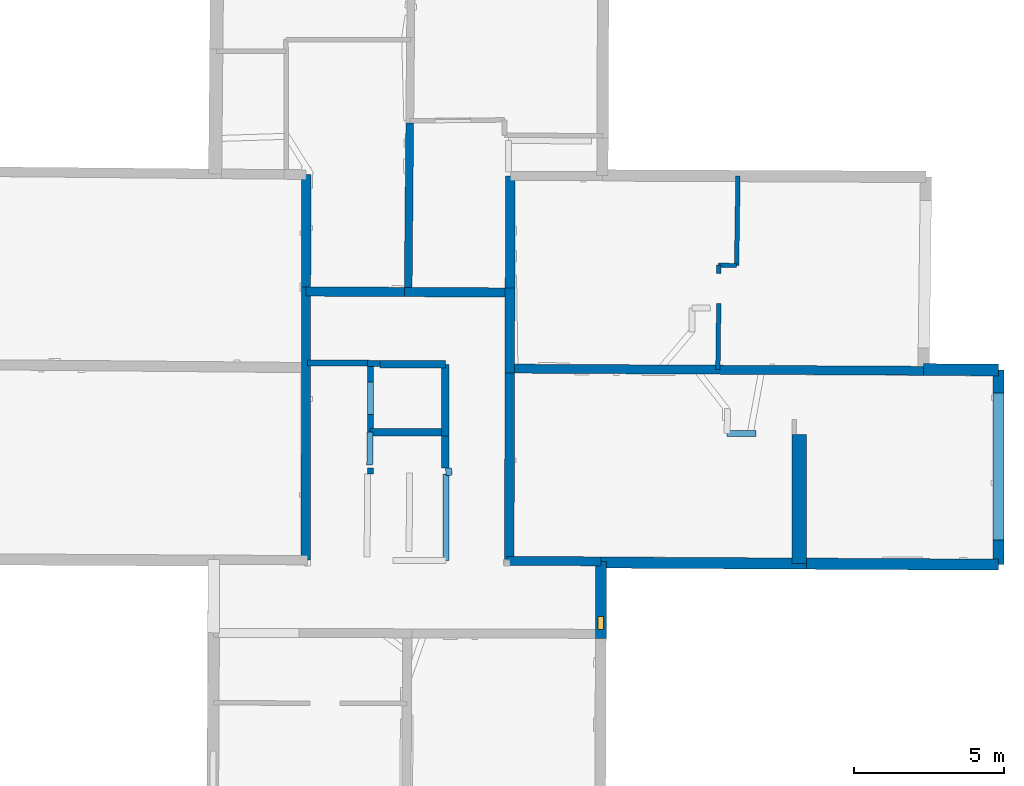
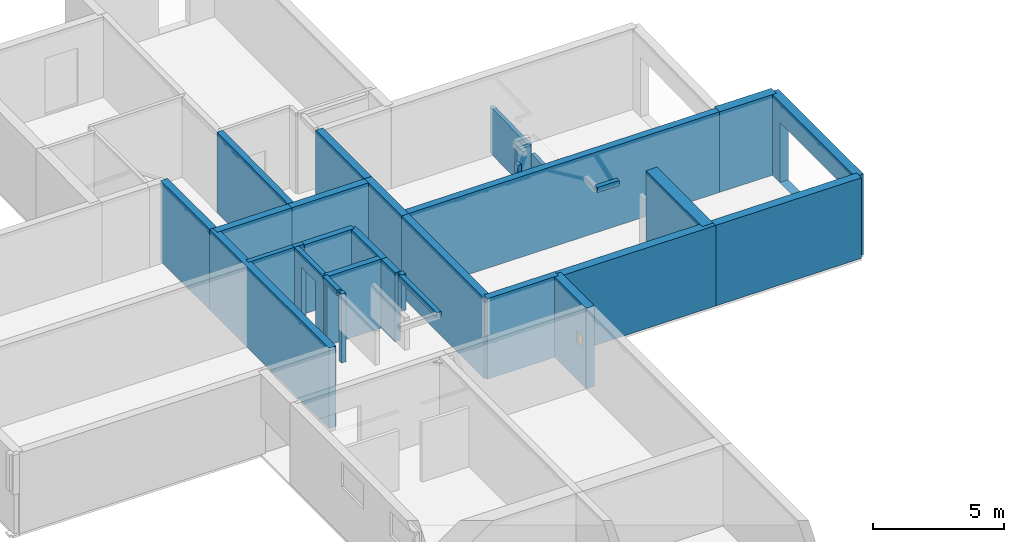
# One storey, part 6 of 12: 32 walls, 1 window, 3 openings.
"""IFC2X3 building model written with IfcOpenShell, lengths in metres."""

from ifc_helpers import new_model, entity, si_unit, converted_unit, derived_unit, direction, frame, frame_2d, origin, origin_2d_with_axis, place, context, subcontext, project, spatial, polyline, rectangle, outline, extrude, source, transform, mapped, material, layer, layer_set, layer_usage, type_object, type_shapes, element, fill, save


model = new_model("IFC2X3")

# Units and contexts
model_context = context("Model", 3, precision=1e-05, world=origin(), true_north=direction((0.0, 1.0)))
body_context = subcontext(model_context, "Body", "Model", "MODEL_VIEW")
ifc_project = project(units=[si_unit("LENGTHUNIT", "METRE"), si_unit("AREAUNIT", "SQUARE_METRE"), si_unit("VOLUMEUNIT", "CUBIC_METRE"), converted_unit("PLANEANGLEUNIT", "DEGREE", entity("IfcRatioMeasure", 0.0174532925199433), si_unit("PLANEANGLEUNIT", "RADIAN"), dimensions=[0, 0, 0, 0, 0, 0, 0]), si_unit("MASSUNIT", "GRAM", prefix="KILO"), derived_unit("MASSDENSITYUNIT", [(si_unit("MASSUNIT", "GRAM", prefix="KILO"), 1), (si_unit("LENGTHUNIT", "METRE"), -3)]), derived_unit("MOMENTOFINERTIAUNIT", [(si_unit("LENGTHUNIT", "METRE"), 4)]), si_unit("TIMEUNIT", "SECOND"), si_unit("FREQUENCYUNIT", "HERTZ"), si_unit("THERMODYNAMICTEMPERATUREUNIT", "DEGREE_CELSIUS"), derived_unit("THERMALTRANSMITTANCEUNIT", [(si_unit("MASSUNIT", "GRAM", prefix="KILO"), 1), (si_unit("THERMODYNAMICTEMPERATUREUNIT", "KELVIN"), -1), (si_unit("TIMEUNIT", "SECOND"), -3)]), derived_unit("VOLUMETRICFLOWRATEUNIT", [(si_unit("LENGTHUNIT", "METRE"), 3), (si_unit("TIMEUNIT", "SECOND"), -1)]), si_unit("ELECTRICCURRENTUNIT", "AMPERE"), si_unit("ELECTRICVOLTAGEUNIT", "VOLT"), si_unit("POWERUNIT", "WATT"), si_unit("FORCEUNIT", "NEWTON", prefix="KILO"), si_unit("ILLUMINANCEUNIT", "LUX"), si_unit("LUMINOUSFLUXUNIT", "LUMEN"), si_unit("LUMINOUSINTENSITYUNIT", "CANDELA"), derived_unit("USERDEFINED", [(si_unit("MASSUNIT", "GRAM", prefix="KILO"), -1), (si_unit("LENGTHUNIT", "METRE"), -2), (si_unit("TIMEUNIT", "SECOND"), 3), (si_unit("LUMINOUSFLUXUNIT", "LUMEN"), 1)]), derived_unit("LINEARVELOCITYUNIT", [(si_unit("LENGTHUNIT", "METRE"), 1), (si_unit("TIMEUNIT", "SECOND"), -1)]), si_unit("PRESSUREUNIT", "PASCAL"), derived_unit("USERDEFINED", [(si_unit("LENGTHUNIT", "METRE"), -2), (si_unit("MASSUNIT", "GRAM", prefix="KILO"), 1), (si_unit("TIMEUNIT", "SECOND"), -2)]), derived_unit("LINEARFORCEUNIT", [(si_unit("MASSUNIT", "GRAM", prefix="KILO"), 1), (si_unit("LENGTHUNIT", "METRE"), 1), (si_unit("TIMEUNIT", "SECOND"), -2), (si_unit("LENGTHUNIT", "METRE"), -1)]), derived_unit("PLANARFORCEUNIT", [(si_unit("MASSUNIT", "GRAM", prefix="KILO"), 1), (si_unit("LENGTHUNIT", "METRE"), 1), (si_unit("TIMEUNIT", "SECOND"), -2), (si_unit("LENGTHUNIT", "METRE"), -2)])], contexts=[model_context])

# Site, building, storey
placement_1 = place(None, origin())
site = spatial("IfcSite", under=ifc_project, at=placement_1, CompositionType="ELEMENT")
building = spatial("IfcBuilding", under=site, at=placement_1, CompositionType="ELEMENT")
storey_placement = place(placement_1, frame((0.0, 0.0, -1.46125340461731)))
storey = spatial("IfcBuildingStorey", under=building, at=storey_placement, Name="Level 1", CompositionType="ELEMENT", Elevation=-1.46125340461731)

# Walls
ifc_material_1 = material(Name="Default wall")
ifc_layer_1 = layer(ifc_material_1, 0.25)
ifc_layer_set_1 = layer_set([ifc_layer_1], Name="wall_thickness_0.2500")
ifc_layer_usage_1 = layer_usage(ifc_layer_set_1, "AXIS2", "POSITIVE", -0.125)
wall_type_1 = type_object("IfcWallType", Name="wall_thickness_0.2500", PredefinedType="STANDARD", material=ifc_layer_set_1)
placement_2 = place(placement_1, frame((0.0, 0.0, -0.920999705791473)))
wall_1_placement = place(placement_2, frame((5.0991297330923, 55.5079187408588, 0.0), z_axis=(0.0, 0.0, 1.0), x_axis=(0.999995431107156, -0.0030228736017967, 0.0)))
element("IfcWallStandardCase", 1, at=wall_1_placement, inside=storey, type_object=wall_type_1, material=ifc_layer_usage_1, Name="Wall:584", ObjectType="Wall", context=body_context, shape_type="SweptSolid", body=[
    extrude(outline(polyline([(2.50622082412851, -0.125), (2.50622082412851, 0.125), (0.0, 0.125), (0.0, -0.125), (2.50622082412851, -0.125)])), origin(), (0.0, 0.0, 1.0), 3.20173248052597),
])
placement_3 = place(placement_1, frame((0.0, 0.0, -0.920999705791473)))
wall_2_placement = place(placement_3, frame((5.42314035019711, 57.770520756905, 0.0), z_axis=(0.0, 0.0, 1.0), x_axis=(0.999988008085666, -0.00489731404561275, 0.0)))
element("IfcWallStandardCase", 2, at=wall_2_placement, inside=storey, type_object=wall_type_1, material=ifc_layer_usage_1, Name="Wall:603", ObjectType="Wall", context=body_context, shape_type="SweptSolid", body=[
    extrude(outline(polyline([(2.18258041831252, -0.125), (2.18258041831252, 0.125), (0.0, 0.125), (0.0, -0.125), (2.18258041831252, -0.125)])), origin(), (0.0, 0.0, 1.0), 3.20173248052597),
])
placement_4 = place(placement_1, frame((0.0, 0.0, -0.920999705791473)))
wall_3_placement = place(placement_4, frame((7.60569477235314, 57.7598348384197, 0.0), z_axis=(0.0, 0.0, 1.0), x_axis=(-0.00015717987903363, -0.999999987647243, 0.0)))
element("IfcWallStandardCase", 3, at=wall_3_placement, inside=storey, type_object=wall_type_1, material=ifc_layer_usage_1, Name="Wall:614", ObjectType="Wall", context=body_context, shape_type="SweptSolid", body=[
    extrude(outline(polyline([(2.38449099625191, -0.125), (2.38449099625191, 0.125), (0.0, 0.125), (0.0, -0.125), (2.38449099625191, -0.125)])), origin(), (0.0, 0.0, 1.0), 3.20173248052597),
])
placement_5 = place(placement_1, frame((0.0, 0.0, -0.920999705791473)))
wall_4_placement = place(placement_5, frame((7.60531997834679, 55.3753438716228, 0.0), z_axis=(0.0, 0.0, 1.0), x_axis=(-0.000157016468550762, -0.999999987672914, 0.0)))
element("IfcWallStandardCase", 4, at=wall_4_placement, inside=storey, type_object=wall_type_1, material=ifc_layer_usage_1, Name="Wall:615", ObjectType="Wall", context=body_context, shape_type="SweptSolid", body=[
    extrude(outline(polyline([(1.05682755819362, -0.125), (1.05682755819362, 0.125), (0.0, 0.125), (0.0, -0.125), (1.05682755819362, -0.125)])), origin(), (0.0, 0.0, 1.0), 3.20173248052597),
])
ifc_layer_2 = layer(ifc_material_1, 0.2)
ifc_layer_set_2 = layer_set([ifc_layer_2], Name="wall_thickness_0.2000")
ifc_layer_usage_2 = layer_usage(ifc_layer_set_2, "AXIS2", "POSITIVE", -0.1)
wall_type_2 = type_object("IfcWallType", Name="wall_thickness_0.2000", PredefinedType="STANDARD", material=ifc_layer_set_2)
placement_6 = place(placement_1, frame((0.0, 0.0, 2.04199981689453)))
wall_5_placement = place(placement_6, frame((16.9757748002958, 55.4680153708994, 0.0), z_axis=(0.0, 0.0, 1.0), x_axis=(0.99996270094869, -0.00863693877487449, 0.0)))
element("IfcWallStandardCase", 5, at=wall_5_placement, inside=storey, type_object=wall_type_2, material=ifc_layer_usage_2, Name="Wall:542", ObjectType="Wall", context=body_context, shape_type="SweptSolid", body=[
    extrude(outline(polyline([(0.957545710053407, -0.1), (0.957545710053407, 0.1), (0.0, 0.1), (0.0, -0.1), (0.957545710053407, -0.1)])), origin(), (0.0, 0.0, 1.0), 0.238732957839966),
])
placement_7 = place(placement_1, frame((0.0, 0.0, 0.585000038146973)))
wall_6_placement = place(placement_7, frame((7.71784101377591, 54.0699024277879, 0.0), z_axis=(0.0, 0.0, 1.0), x_axis=(-0.0227928941877033, 0.999740208241395, 0.0)))
element("IfcWallStandardCase", 6, at=wall_6_placement, inside=storey, type_object=wall_type_2, material=ifc_layer_usage_2, Name="Wall:550", ObjectType="Wall", context=body_context, shape_type="SweptSolid", body=[
    extrude(outline(polyline([(0.239999178421907, -0.1), (0.239999178421907, 0.1), (0.0, 0.1), (0.0, -0.1), (0.239999178421907, -0.1)])), origin(), (0.0, 0.0, 1.0), 1.69573273658752),
])
placement_8 = place(placement_1, frame((0.0, 0.0, 2.04199981689453)))
wall_7_placement = place(placement_8, frame((5.08565149901211, 54.4163982963928, 0.0), z_axis=(0.0, 0.0, 1.0), x_axis=(0.0123472078364718, 0.99992377032384, 0.0)))
element("IfcWallStandardCase", 7, at=wall_7_placement, inside=storey, type_object=wall_type_2, material=ifc_layer_usage_2, Name="Wall:597", ObjectType="Wall", context=body_context, shape_type="SweptSolid", body=[
    extrude(outline(polyline([(1.09160542952526, -0.1), (1.09160542952526, 0.1), (0.0, 0.1), (0.0, -0.1), (1.09160542952526, -0.1)])), origin(), (0.0, 0.0, 1.0), 0.238732957839966),
])
placement_9 = place(placement_1, frame((0.0, 0.0, -0.920999705791473)))
wall_8_placement = place(placement_9, frame((3.00986537965636, 57.807349833775, 0.0), z_axis=(0.0, 0.0, 1.0), x_axis=(0.999987997594505, -0.00489945577916829, 0.0)))
element("IfcWallStandardCase", 8, at=wall_8_placement, inside=storey, type_object=wall_type_2, material=ifc_layer_usage_2, Name="Wall:601", ObjectType="Wall", context=body_context, shape_type="SweptSolid", body=[
    extrude(outline(polyline([(1.9970990508642, -0.1), (1.9970990508642, 0.1), (0.0, 0.1), (0.0, -0.1), (1.9970990508642, -0.1)])), origin(), (0.0, 0.0, 1.0), 3.20173248052597),
])
placement_10 = place(placement_1, frame((0.0, 0.0, -0.920999705791473)))
wall_9_placement = place(placement_10, frame((5.00694046052794, 57.7975651352887, 0.0), z_axis=(0.0, 0.0, 1.0), x_axis=(0.999987984808634, -0.00490206470457369, 0.0)))
element("IfcWallStandardCase", 9, at=wall_9_placement, inside=storey, type_object=wall_type_2, material=ifc_layer_usage_2, Name="Wall:602", ObjectType="Wall", context=body_context, shape_type="SweptSolid", body=[
    extrude(outline(polyline([(0.416327233544107, -0.1), (0.416327233544107, 0.1), (0.0, 0.1), (0.0, -0.1), (0.416327233544107, -0.1)])), origin(), (0.0, 0.0, 1.0), 3.20173248052597),
])
placement_11 = place(placement_1, frame((0.0, 0.0, -0.920999705791473)))
wall_10_placement = place(placement_11, frame((5.11326645856321, 54.3175500420287, 0.0), z_axis=(0.0, 0.0, 1.0), x_axis=(-0.0103440014207659, -0.999946499386146, 0.0)))
element("IfcWallStandardCase", 10, at=wall_10_placement, inside=storey, type_object=wall_type_2, material=ifc_layer_usage_2, Name="Wall:642", ObjectType="Wall", context=body_context, shape_type="SweptSolid", body=[
    extrude(outline(polyline([(0.204997539759841, -0.1), (0.204997539759841, 0.1), (0.0, 0.1), (0.0, -0.1), (0.204997539759841, -0.1)])), origin(), (0.0, 0.0, 1.0), 3.20173248052597),
])

# Wall, opening
placement_12 = place(placement_1, frame((0.0, 0.0, -0.920999705791473)))
wall_11_placement = place(placement_12, frame((5.1182845221847, 55.507865807687, 0.0), z_axis=(0.0, 0.0, 1.0), x_axis=(-0.00495805451237965, 0.999987708772189, 0.0)))
wall_11 = element("IfcWallStandardCase", 11, at=wall_11_placement, inside=storey, type_object=wall_type_2, material=ifc_layer_usage_2, Name="Wall:677", ObjectType="Wall", context=body_context, shape_type="SweptSolid", body=[
    extrude(outline(polyline([(2.28923559601232, -0.1), (2.28923559601232, 0.1), (0.0, 0.1), (0.0, -0.1), (2.28923559601232, -0.1)])), origin(), (0.0, 0.0, 1.0), 3.20173248052597),
])
opening_1_placement = place(wall_11_placement, frame((0.577159338640721, -0.1, 0.0170002579689026)))
element("IfcOpeningElement", 12, at=opening_1_placement, cuts=wall_11, Name="Opening : 1085 x 2585 : 430", ObjectType="Opening", context=body_context, shape_type="SweptSolid", body=[
    extrude(rectangle(XDim=1.085, YDim=2.585, at=frame_2d((1.2925, 0.5425), x_axis=(0.0, 1.0))), frame((0.0, 0.0, 0.0), z_axis=(0.0, 1.0, 0.0), x_axis=(0.0, 0.0, 1.0)), (0.0, 0.0, 1.0), 0.2),
])

# Wall
ifc_layer_3 = layer(ifc_material_1, 0.259999990463257)
ifc_layer_set_3 = layer_set([ifc_layer_3], Name="wall_thickness_0.2600")
ifc_layer_usage_3 = layer_usage(ifc_layer_set_3, "AXIS2", "POSITIVE", -0.129999995231628)
wall_type_3 = type_object("IfcWallType", Name="wall_thickness_0.2600", PredefinedType="STANDARD", material=ifc_layer_set_3)
wall_12_placement = place(storey_placement, frame((6.41707185678893, 65.78650920034, 0.0), z_axis=(0.0, 0.0, 1.0), x_axis=(-0.00925303609033537, -0.999957189745197, 0.0)))
element("IfcWallStandardCase", 13, at=wall_12_placement, inside=storey, type_object=wall_type_3, material=ifc_layer_usage_3, Name="Wall:624", ObjectType="Wall", context=body_context, shape_type="SweptSolid", body=[
    extrude(outline(polyline([(5.61936974755893, -0.129999995231628), (5.61936974755893, 0.129999995231628), (0.0, 0.129999995231628), (0.0, -0.129999995231628), (5.61936974755893, -0.129999995231628)])), origin(), (0.0, 0.0, 1.0), 3.74198617935181),
])

# Wall, opening
ifc_layer_4 = layer(ifc_material_1, 0.370000004768372)
ifc_layer_set_4 = layer_set([ifc_layer_4], Name="wall_thickness_0.3700")
ifc_layer_usage_4 = layer_usage(ifc_layer_set_4, "AXIS2", "POSITIVE", -0.185000002384186)
wall_type_4 = type_object("IfcWallType", Name="wall_thickness_0.3700", PredefinedType="STANDARD", material=ifc_layer_set_4)
wall_13_placement = place(storey_placement, frame((26.0007051826948, 57.5693012363224, 0.0), z_axis=(0.0, 0.0, 1.0), x_axis=(-3.9191118849826e-05, -0.999999999232028, 0.0)))
wall_13 = element("IfcWallStandardCase", 14, at=wall_13_placement, inside=storey, type_object=wall_type_4, material=ifc_layer_usage_4, Name="Wall:523", ObjectType="Wall", context=body_context, shape_type="SweptSolid", body=[
    extrude(outline(polyline([(6.4728279163479, -0.185000002384186), (6.4728279163479, 0.185000002384186), (0.0, 0.185000002384186), (0.0, -0.185000002384186), (6.4728279163479, -0.185000002384186)])), origin(), (0.0, 0.0, 1.0), 3.74198617935181),
])
opening_2_placement = place(wall_13_placement, frame((0.755805979989141, -0.185000002384186, 0.00725388526916504)))
element("IfcOpeningElement", 15, at=opening_2_placement, cuts=wall_13, Name="Opening : 4900 x 2770 : 407", ObjectType="Opening", context=body_context, shape_type="SweptSolid", body=[
    extrude(rectangle(XDim=4.9, YDim=2.77, at=frame_2d((1.385, 2.45), x_axis=(0.0, 1.0))), frame((0.0, 0.0, 0.0), z_axis=(0.0, 1.0, 0.0), x_axis=(0.0, 0.0, 1.0)), (0.0, 0.0, 1.0), 0.370000004768372),
])

# Walls
wall_14_placement = place(storey_placement, frame((12.7834272632515, 51.1682316821907, 0.0), z_axis=(0.0, 0.0, 1.0), x_axis=(0.99998526317627, -0.00542894375427323, 0.0)))
element("IfcWallStandardCase", 16, at=wall_14_placement, inside=storey, type_object=wall_type_4, material=ifc_layer_usage_4, Name="Wall:563", ObjectType="Wall", context=body_context, shape_type="SweptSolid", body=[
    extrude(outline(polyline([(6.83476602120401, -0.185000002384186), (6.83476602120401, 0.185000002384186), (0.0, 0.185000002384186), (0.0, -0.185000002384186), (6.83476602120401, -0.185000002384186)])), origin(), (0.0, 0.0, 1.0), 3.74198617935181),
])
wall_15_placement = place(storey_placement, frame((19.6180925617134, 51.1311261218879, 0.0), z_axis=(0.0, 0.0, 1.0), x_axis=(0.999985264095711, -0.00542877439489841, 0.0)))
element("IfcWallStandardCase", 17, at=wall_15_placement, inside=storey, type_object=wall_type_4, material=ifc_layer_usage_4, Name="Wall:564", ObjectType="Wall", context=body_context, shape_type="SweptSolid", body=[
    extrude(outline(polyline([(6.38245260223607, -0.185000002384186), (6.38245260223607, 0.185000002384186), (0.0, 0.185000002384186), (0.0, -0.185000002384186), (6.38245260223607, -0.185000002384186)])), origin(), (0.0, 0.0, 1.0), 3.74198617935181),
])
ifc_layer_5 = layer(ifc_material_1, 0.200000002980232)
ifc_layer_set_5 = layer_set([ifc_layer_5], Name="wall_thickness_0.2000")
ifc_layer_usage_5 = layer_usage(ifc_layer_set_5, "AXIS2", "POSITIVE", -0.100000001490116)
wall_type_5 = type_object("IfcWallType", Name="wall_thickness_0.2000", PredefinedType="STANDARD", material=ifc_layer_set_5)
placement_13 = place(placement_1, frame((0.0, 0.0, 2.04199981689453)))
wall_16_placement = place(placement_13, frame((7.62385456722978, 54.1144323630096, 0.0), z_axis=(0.0, 0.0, 1.0), x_axis=(0.00073438058319397, -0.999999730342543, 0.0)))
element("IfcWallStandardCase", 18, at=wall_16_placement, inside=storey, type_object=wall_type_5, material=ifc_layer_usage_5, Name="Wall:616", ObjectType="Wall", context=body_context, shape_type="SweptSolid", body=[
    extrude(outline(polyline([(2.88681108118451, -0.100000001490116), (2.88681108118451, 0.100000001490116), (0.0, 0.100000001490116), (0.0, -0.100000001490116), (2.88681108118451, -0.100000001490116)])), origin(), (0.0, 0.0, 1.0), 0.238732957839966),
])
ifc_layer_6 = layer(ifc_material_1, 0.389999985694885)
ifc_layer_set_6 = layer_set([ifc_layer_6], Name="wall_thickness_0.3900")
ifc_layer_usage_6 = layer_usage(ifc_layer_set_6, "AXIS2", "POSITIVE", -0.194999992847443)
wall_type_6 = type_object("IfcWallType", Name="wall_thickness_0.3900", PredefinedType="STANDARD", material=ifc_layer_set_6)
wall_17_placement = place(storey_placement, frame((23.5122584294612, 57.589258447054, 0.0), z_axis=(0.0, 0.0, 1.0), x_axis=(0.999967837695735, -0.0080201978851629, 0.0)))
element("IfcWallStandardCase", 19, at=wall_17_placement, inside=storey, type_object=wall_type_6, material=ifc_layer_usage_6, Name="Wall:665", ObjectType="Wall", context=body_context, shape_type="SweptSolid", body=[
    extrude(outline(polyline([(2.48852913351085, -0.194999992847443), (2.48852913351085, 0.194999992847443), (0.0, 0.194999992847443), (0.0, -0.194999992847443), (2.48852913351085, -0.194999992847443)])), origin(), (0.0, 0.0, 1.0), 3.74198617935181),
])

# Wall, opening, window
ifc_layer_7 = layer(ifc_material_1, 0.360000014305115)
ifc_layer_set_7 = layer_set([ifc_layer_7], Name="wall_thickness_0.3600")
ifc_layer_usage_7 = layer_usage(ifc_layer_set_7, "AXIS2", "POSITIVE", -0.180000007152557)
wall_type_7 = type_object("IfcWallType", Name="wall_thickness_0.3600", PredefinedType="STANDARD", material=ifc_layer_set_7)
wall_18_placement = place(storey_placement, frame((12.7835708286866, 51.2071034213445, 0.0), z_axis=(0.0, 0.0, 1.0), x_axis=(-0.003643769556498, -0.999993361449674, 0.0)))
wall_18 = element("IfcWallStandardCase", 20, at=wall_18_placement, inside=storey, type_object=wall_type_7, material=ifc_layer_usage_7, Name="Wall:587", ObjectType="Wall", context=body_context, shape_type="SweptSolid", body=[
    extrude(outline(polyline([(2.56100256652997, -0.180000007152557), (2.56100256652997, 0.180000007152557), (0.0, 0.180000007152557), (0.0, -0.180000007152557), (2.56100256652997, -0.180000007152557)])), origin(), (0.0, 0.0, 1.0), 3.74198617935181),
])
opening_3_placement = place(wall_18_placement, frame((1.83679649454759, -0.180000007152557, 1.71925365924835)))
opening_3 = element("IfcOpeningElement", 21, at=opening_3_placement, cuts=wall_18, Name="Opening : 425 x 550 : 417", ObjectType="Opening", context=body_context, shape_type="SweptSolid", body=[
    extrude(rectangle(XDim=0.425, YDim=0.55, at=frame_2d((0.275, 0.2125), x_axis=(0.0, 1.0))), frame((0.0, 0.0, 0.0), z_axis=(0.0, 1.0, 0.0), x_axis=(0.0, 0.0, 1.0)), (0.0, 0.0, 1.0), 0.360000014305115),
])
ifc_material_2 = material(Name="Window Default")
window_style = type_object("IfcWindowStyle", Name="Window : 425 x 550mm", ConstructionType="NOTDEFINED", OperationType="NOTDEFINED", ParameterTakesPrecedence=False, Sizeable=False, material=ifc_material_2)
shared_shape = source(origin(), body_context, "Body", "SweptSolid", [
    extrude(rectangle(XDim=0.180000007152557, YDim=0.425, at=origin_2d_with_axis()), frame((0.2125, 0.180000007152557, 0.0), z_axis=(0.0, 0.0, 1.0), x_axis=(0.0, 1.0, 0.0)), (0.0, 0.0, 1.0), 0.55),
])
type_shapes(window_style, [shared_shape])
window_placement = place(opening_3_placement, origin())
window = element("IfcWindow", 22, at=window_placement, inside=storey, type_object=window_style, Name="Window : 425 x 550mm : 232", ObjectType="Window : 425 x 550mm", OverallHeight=0.55, OverallWidth=0.425, context=body_context, shape_type="MappedRepresentation", body=[
    mapped(shared_shape, transform((0.0, 0.0, 0.0), scale=1.0)),
])
fill(opening_3, window)

# Walls
ifc_layer_8 = layer(ifc_material_1, 0.150000005960464)
ifc_layer_set_8 = layer_set([ifc_layer_8], Name="wall_thickness_0.1500")
ifc_layer_usage_8 = layer_usage(ifc_layer_set_8, "AXIS2", "POSITIVE", -0.0750000029802322)
wall_type_8 = type_object("IfcWallType", Name="wall_thickness_0.1500", PredefinedType="STANDARD", material=ifc_layer_set_8)
wall_19_placement = place(storey_placement, frame((16.6969586935665, 59.7852968585251, 0.0), z_axis=(0.0, 0.0, 1.0), x_axis=(-0.0133846944718258, -0.999910420964746, 0.0)))
element("IfcWallStandardCase", 23, at=wall_19_placement, inside=storey, type_object=wall_type_8, material=ifc_layer_usage_8, Name="Wall:527", ObjectType="Wall", context=body_context, shape_type="SweptSolid", body=[
    extrude(outline(polyline([(2.20365427988653, -0.0750000029802322), (2.20365427988653, 0.0750000029802322), (0.0, 0.0750000029802322), (0.0, -0.0750000029802322), (2.20365427988653, -0.0750000029802322)])), origin(), (0.0, 0.0, 1.0), 2.75525379180908),
])
wall_20_placement = place(storey_placement, frame((17.3348378419463, 64.0266294087322, 0.0), z_axis=(0.0, 0.0, 1.0), x_axis=(-0.0145092089076731, -0.99989473588817, 0.0)))
element("IfcWallStandardCase", 24, at=wall_20_placement, inside=storey, type_object=wall_type_8, material=ifc_layer_usage_8, Name="Wall:530", ObjectType="Wall", context=body_context, shape_type="SweptSolid", body=[
    extrude(outline(polyline([(2.97475847832671, -0.0750000029802322), (2.97475847832671, 0.0750000029802322), (0.0, 0.0750000029802322), (0.0, -0.0750000029802322), (2.97475847832671, -0.0750000029802322)])), origin(), (0.0, 0.0, 1.0), 2.17325305938721),
])
wall_21_placement = place(storey_placement, frame((16.6890501695518, 61.0608509043501, 0.0), z_axis=(0.0, 0.0, 1.0), x_axis=(0.0140094471705419, -0.999901862879541, 0.0)))
element("IfcWallStandardCase", 25, at=wall_21_placement, inside=storey, type_object=wall_type_8, material=ifc_layer_usage_8, Name="Wall:567", ObjectType="Wall", context=body_context, shape_type="SweptSolid", body=[
    extrude(outline(polyline([(0.276379051755232, -0.0750000029802322), (0.276379051755232, 0.0750000029802322), (0.0, 0.0750000029802322), (0.0, -0.0750000029802322), (0.276379051755232, -0.0750000029802322)])), origin(), (0.0, 0.0, 1.0), 1.60625338554382),
])
ifc_layer_9 = layer(ifc_material_1, 0.319999992847443)
ifc_layer_set_9 = layer_set([ifc_layer_9], Name="wall_thickness_0.3200")
ifc_layer_usage_9 = layer_usage(ifc_layer_set_9, "AXIS2", "POSITIVE", -0.159999996423721)
wall_type_9 = type_object("IfcWallType", Name="wall_thickness_0.3200", PredefinedType="STANDARD", material=ifc_layer_set_9)
wall_22_placement = place(storey_placement, frame((9.76334140786434, 64.0307293730709, 0.0), z_axis=(0.0, 0.0, 1.0), x_axis=(-0.00275428932216568, -0.999996206937971, 0.0)))
element("IfcWallStandardCase", 26, at=wall_22_placement, inside=storey, type_object=wall_type_9, material=ifc_layer_usage_9, Name="Wall:649", ObjectType="Wall", context=body_context, shape_type="SweptSolid", body=[
    extrude(outline(polyline([(3.72531015084029, -0.159999996423721), (3.72531015084029, 0.159999996423721), (0.0, 0.159999996423721), (0.0, -0.159999996423721), (3.72531015084029, -0.159999996423721)])), origin(), (0.0, 0.0, 1.0), 3.74198617935181),
])
wall_23_placement = place(storey_placement, frame((9.75308082589413, 60.3054333525631, 0.0), z_axis=(0.0, 0.0, 1.0), x_axis=(-0.00275438353795459, -0.999996206678468, 0.0)))
element("IfcWallStandardCase", 27, at=wall_23_placement, inside=storey, type_object=wall_type_9, material=ifc_layer_usage_9, Name="Wall:650", ObjectType="Wall", context=body_context, shape_type="SweptSolid", body=[
    extrude(outline(polyline([(2.83673408828122, -0.159999996423721), (2.83673408828122, 0.159999996423721), (0.0, 0.159999996423721), (0.0, -0.159999996423721), (2.83673408828122, -0.159999996423721)])), origin(), (0.0, 0.0, 1.0), 3.74198617935181),
])
wall_24_placement = place(storey_placement, frame((9.74526737221981, 57.4687100249264, 0.0), z_axis=(0.0, 0.0, 1.0), x_axis=(-0.00275437170237044, -0.999996206711068, 0.0)))
element("IfcWallStandardCase", 28, at=wall_24_placement, inside=storey, type_object=wall_type_9, material=ifc_layer_usage_9, Name="Wall:651", ObjectType="Wall", context=body_context, shape_type="SweptSolid", body=[
    extrude(outline(polyline([(6.29880242711308, -0.159999996423721), (6.29880242711308, 0.159999996423721), (0.0, 0.159999996423721), (0.0, -0.159999996423721), (6.29880242711308, -0.159999996423721)])), origin(), (0.0, 0.0, 1.0), 3.74198617935181),
])
ifc_layer_10 = layer(ifc_material_1, 0.300000011920929)
ifc_layer_set_10 = layer_set([ifc_layer_10], Name="wall_thickness_0.3000")
ifc_layer_usage_10 = layer_usage(ifc_layer_set_10, "AXIS2", "POSITIVE", -0.150000005960464)
wall_type_10 = type_object("IfcWallType", Name="wall_thickness_0.3000", PredefinedType="STANDARD", material=ifc_layer_set_10)
wall_25_placement = place(storey_placement, frame((9.65902395556911, 51.2246018054783, 0.0), z_axis=(0.0, 0.0, 1.0), x_axis=(0.999984292018245, -0.00560497250383373, 0.0)))
element("IfcWallStandardCase", 29, at=wall_25_placement, inside=storey, type_object=wall_type_10, material=ifc_layer_usage_10, Name="Wall:555", ObjectType="Wall", context=body_context, shape_type="SweptSolid", body=[
    extrude(outline(polyline([(3.12459608579801, -0.150000005960464), (3.12459608579801, 0.150000005960464), (0.0, 0.150000005960464), (0.0, -0.150000005960464), (3.12459608579801, -0.150000005960464)])), origin(), (0.0, 0.0, 1.0), 3.74198617935181),
])
wall_26_placement = place(storey_placement, frame((9.74568149727859, 57.6187097314293, 0.0), z_axis=(0.0, 0.0, 1.0), x_axis=(0.999985816920232, -0.00532597018168324, 0.0)))
element("IfcWallStandardCase", 30, at=wall_26_placement, inside=storey, type_object=wall_type_10, material=ifc_layer_usage_10, Name="Wall:672", ObjectType="Wall", context=body_context, shape_type="SweptSolid", body=[
    extrude(outline(polyline([(13.7662207906205, -0.150000005960464), (13.7662207906205, 0.150000005960464), (0.0, 0.150000005960464), (0.0, -0.150000005960464), (13.7662207906205, -0.150000005960464)])), origin(), (0.0, 0.0, 1.0), 3.74198617935181),
])
ifc_layer_11 = layer(ifc_material_1, 0.310000002384186)
ifc_layer_set_11 = layer_set([ifc_layer_11], Name="wall_thickness_0.3100")
ifc_layer_usage_11 = layer_usage(ifc_layer_set_11, "AXIS2", "POSITIVE", -0.155000001192093)
wall_type_11 = type_object("IfcWallType", Name="wall_thickness_0.3100", PredefinedType="STANDARD", material=ifc_layer_set_11)
wall_27_placement = place(storey_placement, frame((2.97206396864119, 64.0726198954406, 0.0), z_axis=(0.0, 0.0, 1.0), x_axis=(-0.00101223779386473, -0.999999487687193, 0.0)))
element("IfcWallStandardCase", 31, at=wall_27_placement, inside=storey, type_object=wall_type_11, material=ifc_layer_usage_11, Name="Wall:546", ObjectType="Wall", context=body_context, shape_type="SweptSolid", body=[
    extrude(outline(polyline([(3.73324776220002, -0.155000001192093), (3.73324776220002, 0.155000001192093), (0.0, 0.155000001192093), (0.0, -0.155000001192093), (3.73324776220002, -0.155000001192093)])), origin(), (0.0, 0.0, 1.0), 3.74198617935181),
])
wall_28_placement = place(storey_placement, frame((2.96828503416243, 60.3393740458312, 0.0), z_axis=(0.0, 0.0, 1.0), x_axis=(-0.00101222250441785, -0.999999487702669, 0.0)))
element("IfcWallStandardCase", 32, at=wall_28_placement, inside=storey, type_object=wall_type_11, material=ifc_layer_usage_11, Name="Wall:547", ObjectType="Wall", context=body_context, shape_type="SweptSolid", body=[
    extrude(outline(polyline([(9.09371651171404, -0.155000001192093), (9.09371651171404, 0.155000001192093), (0.0, 0.155000001192093), (0.0, -0.155000001192093), (9.09371651171404, -0.155000001192093)])), origin(), (0.0, 0.0, 1.0), 3.74198617935181),
])
wall_29_placement = place(storey_placement, frame((2.96812779211845, 60.1843764799196, 0.0), z_axis=(0.0, 0.0, 1.0), x_axis=(0.999987483046217, -0.00500337395081078, 0.0)))
element("IfcWallStandardCase", 33, at=wall_29_placement, inside=storey, type_object=wall_type_11, material=ifc_layer_usage_11, Name="Wall:561", ObjectType="Wall", context=body_context, shape_type="SweptSolid", body=[
    extrude(outline(polyline([(3.26699102323829, -0.155000001192093), (3.26699102323829, 0.155000001192093), (0.0, 0.155000001192093), (0.0, -0.155000001192093), (3.26699102323829, -0.155000001192093)])), origin(), (0.0, 0.0, 1.0), 3.74198617935181),
])
wall_30_placement = place(storey_placement, frame((6.23507792258109, 60.1680305021364, 0.0), z_axis=(0.0, 0.0, 1.0), x_axis=(0.999987486994084, -0.00500258485753349, 0.0)))
element("IfcWallStandardCase", 34, at=wall_30_placement, inside=storey, type_object=wall_type_11, material=ifc_layer_usage_11, Name="Wall:562", ObjectType="Wall", context=body_context, shape_type="SweptSolid", body=[
    extrude(outline(polyline([(3.51762118734041, -0.155000001192093), (3.51762118734041, 0.155000001192093), (0.0, 0.155000001192093), (0.0, -0.155000001192093), (3.51762118734041, -0.155000001192093)])), origin(), (0.0, 0.0, 1.0), 3.74198617935181),
])
ifc_layer_12 = layer(ifc_material_1, 0.490000009536743)
ifc_layer_set_12 = layer_set([ifc_layer_12], Name="wall_thickness_0.4900")
ifc_layer_usage_12 = layer_usage(ifc_layer_set_12, "AXIS2", "POSITIVE", -0.245000004768372)
wall_type_12 = type_object("IfcWallType", Name="wall_thickness_0.4900", PredefinedType="STANDARD", material=ifc_layer_set_12)
wall_31_placement = place(storey_placement, frame((19.3745488068212, 55.4235828334577, 0.0), z_axis=(0.0, 0.0, 1.0), x_axis=(-0.000337809587675007, -0.99999994294234, 0.0)))
element("IfcWallStandardCase", 35, at=wall_31_placement, inside=storey, type_object=wall_type_12, material=ifc_layer_usage_12, Name="Wall:629", ObjectType="Wall", context=body_context, shape_type="SweptSolid", body=[
    extrude(outline(polyline([(4.29113031075982, -0.245000004768372), (4.29113031075982, 0.245000004768372), (0.0, 0.245000004768372), (0.0, -0.245000004768372), (4.29113031075982, -0.245000004768372)])), origin(), (0.0, 0.0, 1.0), 3.74198617935181),
])
ifc_layer_13 = layer(ifc_material_1, 0.136977061629295)
ifc_layer_set_13 = layer_set([ifc_layer_13], Name="wall_thickness_0.1370")
ifc_layer_usage_13 = layer_usage(ifc_layer_set_13, "AXIS2", "POSITIVE", -0.0684885308146477)
wall_type_13 = type_object("IfcWallType", Name="wall_thickness_0.1370", PredefinedType="STANDARD", material=ifc_layer_set_13)
wall_32_placement = place(storey_placement, frame((16.6890478133956, 61.0608520508599, 0.0), z_axis=(0.0, 0.0, 1.0), x_axis=(0.999896594755987, -0.014380535295367, 0.0)))
element("IfcWallStandardCase", 36, at=wall_32_placement, inside=storey, type_object=wall_type_13, material=ifc_layer_usage_13, Name="Wall:641", ObjectType="Wall", context=body_context, shape_type="SweptSolid", body=[
    extrude(outline(polyline([(0.602689121752808, -0.0684885308146477), (0.602689121752808, 0.0684885308146477), (0.0, 0.0684885308146477), (0.0, -0.0684885308146477), (0.602689121752808, -0.0684885308146477)])), origin(), (0.0, 0.0, 1.0), 2.17325305938721),
])

save(model, "model.ifc")
